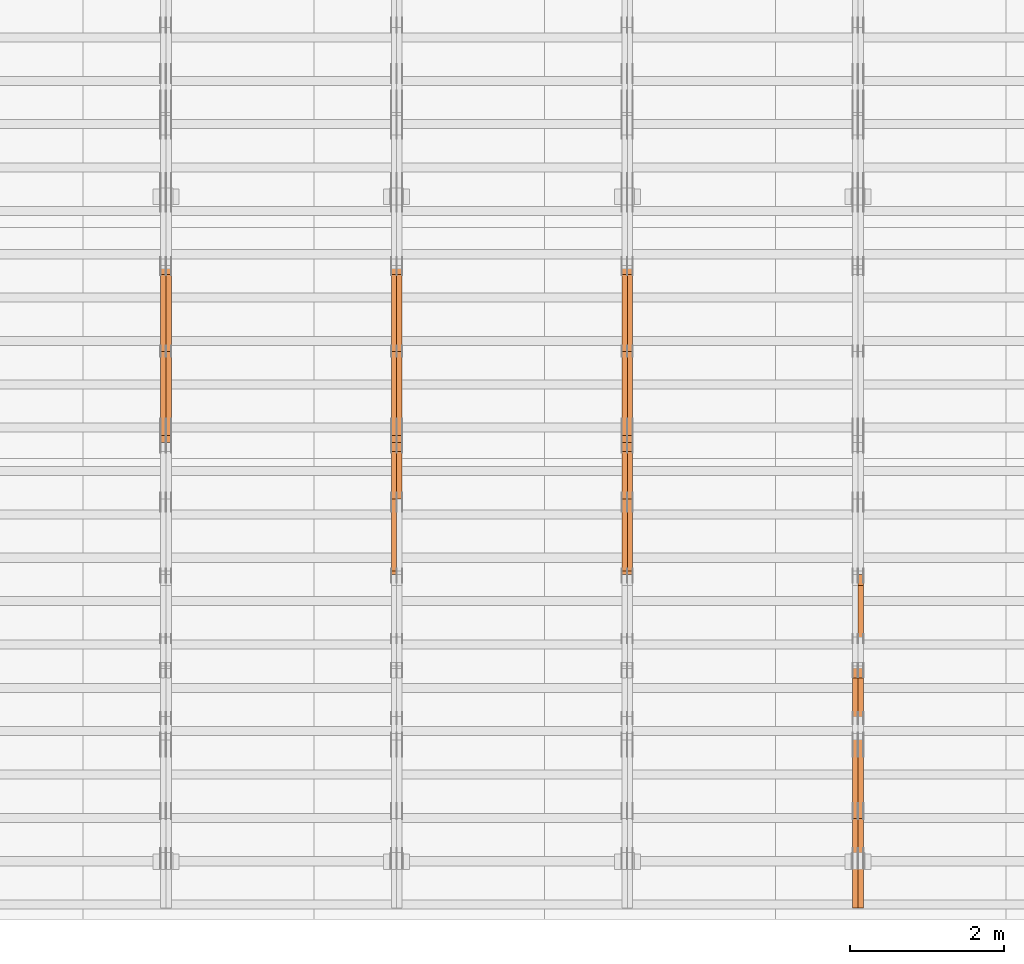
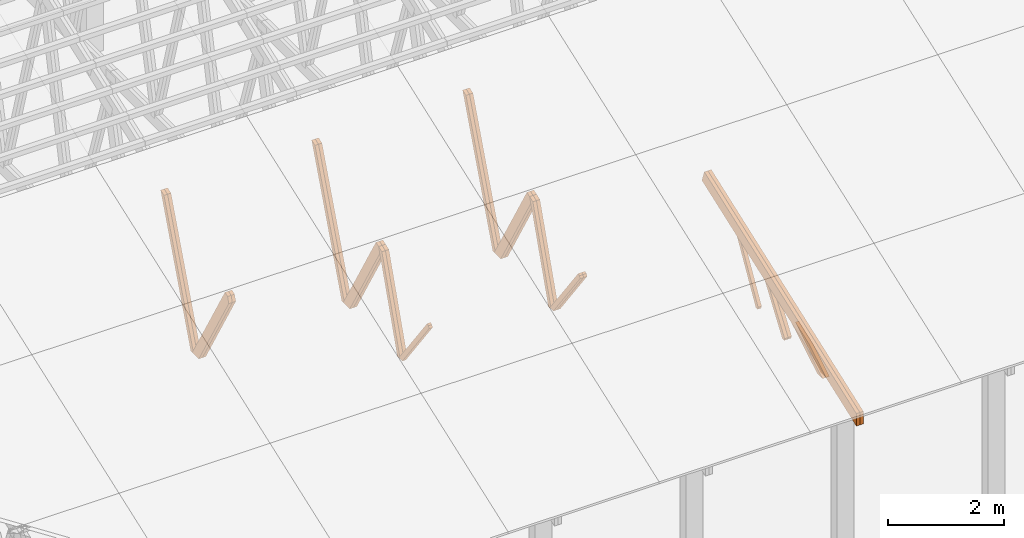
# One storey, part 22 of 189: 26 proxies.
"""IFC2X3 building model written with IfcOpenShell, lengths in millimetres."""

from ifc_helpers import new_model, entity, si_unit, converted_unit, derived_unit, direction, frame, origin, place, context, subcontext, project, spatial, polyline, outline, extrude, source, transform, mapped, material, type_object, type_shapes, element, save


model = new_model("IFC2X3")

# Units and contexts
model_context = context("Model", 3, precision=0.01, world=origin(), true_north=direction((6.12303176911189e-17, 1.0)))
body_context = subcontext(model_context, "Body", "Model", "MODEL_VIEW")
ifc_project = project(units=[si_unit("LENGTHUNIT", "METRE", prefix="MILLI"), si_unit("AREAUNIT", "SQUARE_METRE"), si_unit("VOLUMEUNIT", "CUBIC_METRE"), converted_unit("PLANEANGLEUNIT", "DEGREE", entity("IfcRatioMeasure", 0.0174532925199433), si_unit("PLANEANGLEUNIT", "RADIAN"), dimensions=[0, 0, 0, 0, 0, 0, 0]), si_unit("MASSUNIT", "GRAM", prefix="KILO"), derived_unit("MASSDENSITYUNIT", [(si_unit("MASSUNIT", "GRAM", prefix="KILO"), 1), (si_unit("LENGTHUNIT", "METRE"), -3)]), si_unit("TIMEUNIT", "SECOND"), si_unit("FREQUENCYUNIT", "HERTZ"), si_unit("THERMODYNAMICTEMPERATUREUNIT", "DEGREE_CELSIUS"), derived_unit("THERMALTRANSMITTANCEUNIT", [(si_unit("MASSUNIT", "GRAM", prefix="KILO"), 1), (si_unit("THERMODYNAMICTEMPERATUREUNIT", "KELVIN"), -1), (si_unit("TIMEUNIT", "SECOND"), -3)]), derived_unit("VOLUMETRICFLOWRATEUNIT", [(si_unit("LENGTHUNIT", "METRE"), 3), (si_unit("TIMEUNIT", "SECOND"), -1)]), si_unit("ELECTRICCURRENTUNIT", "AMPERE"), si_unit("ELECTRICVOLTAGEUNIT", "VOLT"), si_unit("POWERUNIT", "WATT"), si_unit("FORCEUNIT", "NEWTON"), si_unit("ILLUMINANCEUNIT", "LUX"), si_unit("LUMINOUSFLUXUNIT", "LUMEN"), si_unit("LUMINOUSINTENSITYUNIT", "CANDELA"), derived_unit("USERDEFINED", [(si_unit("MASSUNIT", "GRAM", prefix="KILO"), -1), (si_unit("LENGTHUNIT", "METRE"), -2), (si_unit("TIMEUNIT", "SECOND"), 3), (si_unit("LUMINOUSFLUXUNIT", "LUMEN"), 1)]), derived_unit("LINEARVELOCITYUNIT", [(si_unit("LENGTHUNIT", "METRE"), 1), (si_unit("TIMEUNIT", "SECOND"), -1)]), si_unit("PRESSUREUNIT", "PASCAL"), derived_unit("USERDEFINED", [(si_unit("LENGTHUNIT", "METRE"), -2), (si_unit("MASSUNIT", "GRAM", prefix="KILO"), 1), (si_unit("TIMEUNIT", "SECOND"), -2)])], contexts=[model_context])

# Site, building, storey
site_placement = place(None, origin())
site = spatial("IfcSite", under=ifc_project, at=site_placement, CompositionType="ELEMENT")
building_placement = place(site_placement, origin())
building = spatial("IfcBuilding", under=site, at=building_placement, CompositionType="ELEMENT")
storey_placement = place(building_placement, origin())
storey = spatial("IfcBuildingStorey", under=building, at=storey_placement, Name="Default", CompositionType="ELEMENT", Elevation=0.0)

# Proxies
ifc_material_1 = material(Name="IfcSurfaceStyle #129154")
building_element_proxy_type_1 = type_object("IfcBuildingElementProxyType", Name="T1-W11 129152", PredefinedType="NOTDEFINED", material=ifc_material_1)
shared_shape_1 = source(origin(), body_context, "Body", "SweptSolid", [
    extrude(outline(polyline([(593.358012843793, -552.565239103314), (742.388662259985, -552.565239103314), (-410.498749190676, 401.275038694583), (-462.246133468927, 382.44069706518), (-463.001792444175, 321.414742446865), (593.358012843793, -552.565239103314)])), frame((599.94412413079, 47.5003788877286, 0.0), z_axis=(0.0, 0.0, 1.0), x_axis=(0.770483455324544, 0.637459994879013, 0.0)), (0.0, 0.0, 1.0), 69.9999999999999),
])
type_shapes(building_element_proxy_type_1, [shared_shape_1])
proxy_1_placement = place(building_placement, frame((24300.0, 2983.26655629375, 269.034992751429), z_axis=(-1.0, 0.0, 0.0), x_axis=(0.0, 0.505995901100606, 0.862535882192379)))
element("IfcBuildingElementProxy", 1, at=proxy_1_placement, inside=storey, type_object=building_element_proxy_type_1, material=ifc_material_1, Name="T1-W11", context=body_context, shape_type="MappedRepresentation", body=[
    mapped(shared_shape_1, transform((0.0, 0.0, 0.0), scale=1.0)),
])
ifc_material_2 = material(Name="IfcSurfaceStyle #128626")
building_element_proxy_type_2 = type_object("IfcBuildingElementProxyType", Name="T1-W13 128624", PredefinedType="NOTDEFINED", material=ifc_material_2)
shared_shape_2 = source(origin(), body_context, "Body", "SweptSolid", [
    extrude(outline(polyline([(404.740440720218, -341.48092914206), (570.336320797765, -341.48092914206), (-287.911826743206, 259.650691447848), (-342.395697357435, 239.820346030744), (-344.769237417342, 183.490820805529), (404.740440720218, -341.48092914206)])), frame((418.029573061951, 47.5005675782689, 0.0), z_axis=(0.0, 0.0, 1.0), x_axis=(0.819070847746389, 0.573692379565924, 0.0)), (0.0, 0.0, 1.0), 69.9999999999999),
])
type_shapes(building_element_proxy_type_2, [shared_shape_2])
proxy_2_placement = place(building_placement, frame((24300.0, 1951.16403402681, 272.239720286334), z_axis=(-1.0, 0.0, 0.0), x_axis=(0.0, 0.573462629043499, 0.819231721242848)))
element("IfcBuildingElementProxy", 2, at=proxy_2_placement, inside=storey, type_object=building_element_proxy_type_2, material=ifc_material_2, Name="T1-W13", context=body_context, shape_type="MappedRepresentation", body=[
    mapped(shared_shape_2, transform((0.0, 0.0, 0.0), scale=1.0)),
])
ifc_material_3 = material(Name="IfcSurfaceStyle #128560")
building_element_proxy_type_3 = type_object("IfcBuildingElementProxyType", Name="T1-W13 128558", PredefinedType="NOTDEFINED", material=ifc_material_3)
shared_shape_3 = source(origin(), body_context, "Body", "SweptSolid", [
    extrude(outline(polyline([(404.740440720218, -341.48092914206), (570.336320797765, -341.48092914206), (-287.911826743206, 259.650691447848), (-342.395697357435, 239.820346030744), (-344.769237417342, 183.490820805529), (404.740440720218, -341.48092914206)])), frame((418.029573061951, 47.5005675782689, 0.0), z_axis=(0.0, 0.0, 1.0), x_axis=(0.819070847746389, 0.573692379565924, 0.0)), (0.0, 0.0, 1.0), 69.9999999999999),
])
type_shapes(building_element_proxy_type_3, [shared_shape_3])
proxy_3_placement = place(building_placement, frame((24230.0, 1951.16403402681, 272.239720286334), z_axis=(-1.0, 0.0, 0.0), x_axis=(0.0, 0.573462629043499, 0.819231721242848)))
element("IfcBuildingElementProxy", 3, at=proxy_3_placement, inside=storey, type_object=building_element_proxy_type_3, material=ifc_material_3, Name="T1-W13", context=body_context, shape_type="MappedRepresentation", body=[
    mapped(shared_shape_3, transform((0.0, 0.0, 0.0), scale=1.0)),
])
ifc_material_4 = material(Name="IfcSurfaceStyle #128098")
building_element_proxy_type_4 = type_object("IfcBuildingElementProxyType", Name="T1-W12 128096", PredefinedType="NOTDEFINED", material=ifc_material_4)
shared_shape_4 = source(origin(), body_context, "Body", "SweptSolid", [
    extrude(outline(polyline([(-671.888430889784, -47.499785620702), (344.892972119224, -47.499785620702), (503.856463083211, 47.4997856207019), (-176.861004312651, 47.499785620702), (-671.888430889784, -47.499785620702)])), frame((503.857114243549, 47.5002636410509, 0.0), z_axis=(0.0, 0.0, 1.0), x_axis=(-1.0, 0.0, 0.0)), (0.0, 0.0, 1.0), 69.9999999999999),
])
type_shapes(building_element_proxy_type_4, [shared_shape_4])
proxy_4_placement = place(building_placement, frame((24300.0, 665.58122707747, 245.000076287477), z_axis=(-1.0, 0.0, 0.0), x_axis=(0.0, 0.858392121304013, 0.51299411895576)))
element("IfcBuildingElementProxy", 4, at=proxy_4_placement, inside=storey, type_object=building_element_proxy_type_4, material=ifc_material_4, Name="T1-W12", context=body_context, shape_type="MappedRepresentation", body=[
    mapped(shared_shape_4, transform((0.0, 0.0, 0.0), scale=1.0)),
])
ifc_material_5 = material(Name="IfcSurfaceStyle #128041")
building_element_proxy_type_5 = type_object("IfcBuildingElementProxyType", Name="T1-W12 128039", PredefinedType="NOTDEFINED", material=ifc_material_5)
shared_shape_5 = source(origin(), body_context, "Body", "SweptSolid", [
    extrude(outline(polyline([(-671.888430889784, -47.499785620702), (344.892972119224, -47.499785620702), (503.856463083211, 47.4997856207019), (-176.861004312651, 47.499785620702), (-671.888430889784, -47.499785620702)])), frame((503.857114243549, 47.5002636410509, 0.0), z_axis=(0.0, 0.0, 1.0), x_axis=(-1.0, 0.0, 0.0)), (0.0, 0.0, 1.0), 69.9999999999999),
])
type_shapes(building_element_proxy_type_5, [shared_shape_5])
proxy_5_placement = place(building_placement, frame((24230.0, 665.58122707747, 245.000076287477), z_axis=(-1.0, 0.0, 0.0), x_axis=(0.0, 0.858392121304013, 0.51299411895576)))
element("IfcBuildingElementProxy", 5, at=proxy_5_placement, inside=storey, type_object=building_element_proxy_type_5, material=ifc_material_5, Name="T1-W12", context=body_context, shape_type="MappedRepresentation", body=[
    mapped(shared_shape_5, transform((0.0, 0.0, 0.0), scale=1.0)),
])
ifc_material_6 = material(Name="IfcSurfaceStyle #127150")
building_element_proxy_type_6 = type_object("IfcBuildingElementProxyType", Name="T1-T2 127148", PredefinedType="NOTDEFINED", material=ifc_material_6)
shared_shape_6 = source(origin(), body_context, "Body", "SweptSolid", [
    extrude(outline(polyline([(-2763.12044548193, -122.499971764318), (2807.70681121203, -122.499971764318), (2807.70678531127, 122.499971764318), (-2852.29315104137, 122.499971764318), (-2763.12044548193, -122.499971764318)])), frame((2807.70684902043, 122.500023191939, 0.0), z_axis=(0.0, 0.0, 1.0), x_axis=(-1.0, 0.0, 0.0)), (0.0, 0.0, 1.0), 69.9999999999997),
])
type_shapes(building_element_proxy_type_6, [shared_shape_6])
proxy_6_placement = place(building_placement, frame((24300.0, 4818.66023370631, 1893.1253396746), z_axis=(-1.0, 0.0, 0.0), x_axis=(0.0, -0.939692620785908, -0.342020143325669)))
element("IfcBuildingElementProxy", 6, at=proxy_6_placement, inside=storey, type_object=building_element_proxy_type_6, material=ifc_material_6, Name="T1-T2", context=body_context, shape_type="MappedRepresentation", body=[
    mapped(shared_shape_6, transform((0.0, 0.0, 0.0), scale=1.0)),
])
ifc_material_7 = material(Name="IfcSurfaceStyle #127093")
building_element_proxy_type_7 = type_object("IfcBuildingElementProxyType", Name="T1-T2 127091", PredefinedType="NOTDEFINED", material=ifc_material_7)
shared_shape_7 = source(origin(), body_context, "Body", "SweptSolid", [
    extrude(outline(polyline([(-2763.12044548193, -122.499971764318), (2807.70681121203, -122.499971764318), (2807.70678531127, 122.499971764318), (-2852.29315104137, 122.499971764318), (-2763.12044548193, -122.499971764318)])), frame((2807.70684902043, 122.500023191939, 0.0), z_axis=(0.0, 0.0, 1.0), x_axis=(-1.0, 0.0, 0.0)), (0.0, 0.0, 1.0), 69.9999999999997),
])
type_shapes(building_element_proxy_type_7, [shared_shape_7])
proxy_7_placement = place(building_placement, frame((24230.0, 4818.66023370631, 1893.1253396746), z_axis=(-1.0, 0.0, 0.0), x_axis=(0.0, -0.939692620785908, -0.342020143325669)))
element("IfcBuildingElementProxy", 7, at=proxy_7_placement, inside=storey, type_object=building_element_proxy_type_7, material=ifc_material_7, Name="T1-T2", context=body_context, shape_type="MappedRepresentation", body=[
    mapped(shared_shape_7, transform((0.0, 0.0, 0.0), scale=1.0)),
])
ifc_material_8 = material(Name="IfcSurfaceStyle #114420")
building_element_proxy_type_8 = type_object("IfcBuildingElementProxyType", Name="T1-W8 114418", PredefinedType="NOTDEFINED", material=ifc_material_8)
shared_shape_8 = source(origin(), body_context, "Body", "SweptSolid", [
    extrude(outline(polyline([(-1781.70529904483, -47.500320228718), (1161.65050357787, -47.5003202287179), (1179.56135870849, 0.000731866266039397), (1140.6022069428, 47.4998218997103), (-1700.10877018433, 47.5000866914596), (-1781.70529904483, -47.500320228718)])), frame((1179.56135870869, 47.5007236522113, 0.0), z_axis=(0.0, 0.0, 1.0), x_axis=(-1.0, 3.74658825645258e-07, 0.0)), (0.0, 0.0, 1.0), 69.9999999999998),
])
type_shapes(building_element_proxy_type_8, [shared_shape_8])
proxy_8_placement = place(building_placement, frame((21300.0, 6723.5697965901, 261.758864533503), z_axis=(-1.0, 0.0, 0.0), x_axis=(0.0, 0.352814979177603, 0.93569310698963)))
element("IfcBuildingElementProxy", 8, at=proxy_8_placement, inside=storey, type_object=building_element_proxy_type_8, material=ifc_material_8, Name="T1-W8", context=body_context, shape_type="MappedRepresentation", body=[
    mapped(shared_shape_8, transform((0.0, 0.0, 0.0), scale=1.0)),
])
ifc_material_9 = material(Name="IfcSurfaceStyle #114354")
building_element_proxy_type_9 = type_object("IfcBuildingElementProxyType", Name="T1-W8 114352", PredefinedType="NOTDEFINED", material=ifc_material_9)
shared_shape_9 = source(origin(), body_context, "Body", "SweptSolid", [
    extrude(outline(polyline([(-1781.70529904483, -47.500320228718), (1161.65050357787, -47.5003202287179), (1179.56135870849, 0.000731866266039397), (1140.6022069428, 47.4998218997103), (-1700.10877018433, 47.5000866914596), (-1781.70529904483, -47.500320228718)])), frame((1179.56135870869, 47.5007236522113, 0.0), z_axis=(0.0, 0.0, 1.0), x_axis=(-1.0, 3.74658825645258e-07, 0.0)), (0.0, 0.0, 1.0), 69.9999999999998),
])
type_shapes(building_element_proxy_type_9, [shared_shape_9])
proxy_9_placement = place(building_placement, frame((21230.0, 6723.5697965901, 261.758864533503), z_axis=(-1.0, 0.0, 0.0), x_axis=(0.0, 0.352814979177603, 0.93569310698963)))
element("IfcBuildingElementProxy", 9, at=proxy_9_placement, inside=storey, type_object=building_element_proxy_type_9, material=ifc_material_9, Name="T1-W8", context=body_context, shape_type="MappedRepresentation", body=[
    mapped(shared_shape_9, transform((0.0, 0.0, 0.0), scale=1.0)),
])
ifc_material_10 = material(Name="IfcSurfaceStyle #114156")
building_element_proxy_type_10 = type_object("IfcBuildingElementProxyType", Name="T1-W2 114154", PredefinedType="NOTDEFINED", material=ifc_material_10)
shared_shape_10 = source(origin(), body_context, "Body", "SweptSolid", [
    extrude(outline(polyline([(-765.033104991319, -1130.91940266317), (-539.905732758898, -1130.91940266317), (493.678280567457, 660.584515081422), (452.144945212405, 783.697385511457), (359.115611970356, 817.556904733455), (-765.033104991319, -1130.91940266317)])), frame((904.774360566371, 97.5002668805543, 0.0), z_axis=(0.0, 0.0, 1.0), x_axis=(-0.499731715721184, 0.866180242387438, 0.0)), (0.0, 0.0, 1.0), 69.9999999999998),
])
type_shapes(building_element_proxy_type_10, [shared_shape_10])
proxy_10_placement = place(building_placement, frame((21300.0, 5635.28919163287, 2208.3400784451), z_axis=(-1.0, 0.0, 0.0), x_axis=(0.0, 0.5, -0.866025403784439)))
element("IfcBuildingElementProxy", 10, at=proxy_10_placement, inside=storey, type_object=building_element_proxy_type_10, material=ifc_material_10, Name="T1-W2", context=body_context, shape_type="MappedRepresentation", body=[
    mapped(shared_shape_10, transform((0.0, 0.0, 0.0), scale=1.0)),
])
ifc_material_11 = material(Name="IfcSurfaceStyle #114090")
building_element_proxy_type_11 = type_object("IfcBuildingElementProxyType", Name="T1-W2 114088", PredefinedType="NOTDEFINED", material=ifc_material_11)
shared_shape_11 = source(origin(), body_context, "Body", "SweptSolid", [
    extrude(outline(polyline([(-765.033104991319, -1130.91940266317), (-539.905732758898, -1130.91940266317), (493.678280567457, 660.584515081422), (452.144945212405, 783.697385511457), (359.115611970356, 817.556904733455), (-765.033104991319, -1130.91940266317)])), frame((904.774360566371, 97.5002668805543, 0.0), z_axis=(0.0, 0.0, 1.0), x_axis=(-0.499731715721184, 0.866180242387438, 0.0)), (0.0, 0.0, 1.0), 69.9999999999998),
])
type_shapes(building_element_proxy_type_11, [shared_shape_11])
proxy_11_placement = place(building_placement, frame((21230.0, 5635.28919163287, 2208.3400784451), z_axis=(-1.0, 0.0, 0.0), x_axis=(0.0, 0.5, -0.866025403784439)))
element("IfcBuildingElementProxy", 11, at=proxy_11_placement, inside=storey, type_object=building_element_proxy_type_11, material=ifc_material_11, Name="T1-W2", context=body_context, shape_type="MappedRepresentation", body=[
    mapped(shared_shape_11, transform((0.0, 0.0, 0.0), scale=1.0)),
])
ifc_material_12 = material(Name="IfcSurfaceStyle #113892")
building_element_proxy_type_12 = type_object("IfcBuildingElementProxyType", Name="T1-W9 113890", PredefinedType="NOTDEFINED", material=ifc_material_12)
shared_shape_12 = source(origin(), body_context, "Body", "SweptSolid", [
    extrude(outline(polyline([(-1227.3969292634, -47.5000382896404), (793.242467803064, -47.5000382896404), (809.267705296822, 1.0956605530188e-05), (776.329919980315, 47.5000328113376), (-1151.4431638168, 47.5000328113376), (-1227.3969292634, -47.5000382896404)])), frame((809.267705296822, 47.5000328113376, 0.0), z_axis=(0.0, 0.0, 1.0), x_axis=(-1.0, 0.0, 0.0)), (0.0, 0.0, 1.0), 69.9999999999999),
])
type_shapes(building_element_proxy_type_12, [shared_shape_12])
proxy_12_placement = place(building_placement, frame((21300.0, 4809.76380889125, 260.184242613649), z_axis=(-1.0, 0.0, 0.0), x_axis=(0.0, 0.31966811847134, 0.947529574226047)))
element("IfcBuildingElementProxy", 12, at=proxy_12_placement, inside=storey, type_object=building_element_proxy_type_12, material=ifc_material_12, Name="T1-W9", context=body_context, shape_type="MappedRepresentation", body=[
    mapped(shared_shape_12, transform((0.0, 0.0, 0.0), scale=1.0)),
])
ifc_material_13 = material(Name="IfcSurfaceStyle #113826")
building_element_proxy_type_13 = type_object("IfcBuildingElementProxyType", Name="T1-W9 113824", PredefinedType="NOTDEFINED", material=ifc_material_13)
shared_shape_13 = source(origin(), body_context, "Body", "SweptSolid", [
    extrude(outline(polyline([(-1227.3969292634, -47.5000382896404), (793.242467803064, -47.5000382896404), (809.267705296822, 1.0956605530188e-05), (776.329919980315, 47.5000328113376), (-1151.4431638168, 47.5000328113376), (-1227.3969292634, -47.5000382896404)])), frame((809.267705296822, 47.5000328113376, 0.0), z_axis=(0.0, 0.0, 1.0), x_axis=(-1.0, 0.0, 0.0)), (0.0, 0.0, 1.0), 69.9999999999999),
])
type_shapes(building_element_proxy_type_13, [shared_shape_13])
proxy_13_placement = place(building_placement, frame((21230.0, 4809.76380889125, 260.184242613649), z_axis=(-1.0, 0.0, 0.0), x_axis=(0.0, 0.31966811847134, 0.947529574226047)))
element("IfcBuildingElementProxy", 13, at=proxy_13_placement, inside=storey, type_object=building_element_proxy_type_13, material=ifc_material_13, Name="T1-W9", context=body_context, shape_type="MappedRepresentation", body=[
    mapped(shared_shape_13, transform((0.0, 0.0, 0.0), scale=1.0)),
])
ifc_material_14 = material(Name="IfcSurfaceStyle #113628")
building_element_proxy_type_14 = type_object("IfcBuildingElementProxyType", Name="T1-W10 113626", PredefinedType="NOTDEFINED", material=ifc_material_14)
shared_shape_14 = source(origin(), body_context, "Body", "SweptSolid", [
    extrude(outline(polyline([(-922.639472665691, -47.5001890573134), (629.920966338637, -47.5001890573134), (650.067737483374, 0.000694680531158376), (635.89112756682, 47.4998417170478), (-993.240358723139, 47.4998417170478), (-922.639472665691, -47.5001890573134)])), frame((650.068202545693, 47.4999816623145, 0.0), z_axis=(0.0, 0.0, 1.0), x_axis=(-1.0, 0.0, 0.0)), (0.0, 0.0, 1.0), 69.9999999999999),
])
type_shapes(building_element_proxy_type_14, [shared_shape_14])
proxy_14_placement = place(building_placement, frame((21300.0, 3874.56126239818, 1563.95828147518), z_axis=(-1.0, 0.0, 0.0), x_axis=(0.0, 0.596486092002, -0.802623412347398)))
element("IfcBuildingElementProxy", 14, at=proxy_14_placement, inside=storey, type_object=building_element_proxy_type_14, material=ifc_material_14, Name="T1-W10", context=body_context, shape_type="MappedRepresentation", body=[
    mapped(shared_shape_14, transform((0.0, 0.0, 0.0), scale=1.0)),
])
ifc_material_15 = material(Name="IfcSurfaceStyle #113562")
building_element_proxy_type_15 = type_object("IfcBuildingElementProxyType", Name="T1-W10 113560", PredefinedType="NOTDEFINED", material=ifc_material_15)
shared_shape_15 = source(origin(), body_context, "Body", "SweptSolid", [
    extrude(outline(polyline([(-922.639472665691, -47.5001890573134), (629.920966338637, -47.5001890573134), (650.067737483374, 0.000694680531158376), (635.89112756682, 47.4998417170478), (-993.240358723139, 47.4998417170478), (-922.639472665691, -47.5001890573134)])), frame((650.068202545693, 47.4999816623145, 0.0), z_axis=(0.0, 0.0, 1.0), x_axis=(-1.0, 0.0, 0.0)), (0.0, 0.0, 1.0), 69.9999999999999),
])
type_shapes(building_element_proxy_type_15, [shared_shape_15])
proxy_15_placement = place(building_placement, frame((21230.0, 3874.56126239818, 1563.95828147518), z_axis=(-1.0, 0.0, 0.0), x_axis=(0.0, 0.596486092002, -0.802623412347398)))
element("IfcBuildingElementProxy", 15, at=proxy_15_placement, inside=storey, type_object=building_element_proxy_type_15, material=ifc_material_15, Name="T1-W10", context=body_context, shape_type="MappedRepresentation", body=[
    mapped(shared_shape_15, transform((0.0, 0.0, 0.0), scale=1.0)),
])
ifc_material_16 = material(Name="IfcSurfaceStyle #98630")
building_element_proxy_type_16 = type_object("IfcBuildingElementProxyType", Name="T1-W8 98628", PredefinedType="NOTDEFINED", material=ifc_material_16)
shared_shape_16 = source(origin(), body_context, "Body", "SweptSolid", [
    extrude(outline(polyline([(-1781.70529904483, -47.500320228718), (1161.65050357787, -47.5003202287179), (1179.56135870849, 0.000731866266039397), (1140.6022069428, 47.4998218997103), (-1700.10877018433, 47.5000866914596), (-1781.70529904483, -47.500320228718)])), frame((1179.56135870869, 47.5007236522113, 0.0), z_axis=(0.0, 0.0, 1.0), x_axis=(-1.0, 3.74658825645258e-07, 0.0)), (0.0, 0.0, 1.0), 69.9999999999998),
])
type_shapes(building_element_proxy_type_16, [shared_shape_16])
proxy_16_placement = place(building_placement, frame((18300.0, 6723.5697965901, 261.758864533503), z_axis=(-1.0, 0.0, 0.0), x_axis=(0.0, 0.352814979177603, 0.93569310698963)))
element("IfcBuildingElementProxy", 16, at=proxy_16_placement, inside=storey, type_object=building_element_proxy_type_16, material=ifc_material_16, Name="T1-W8", context=body_context, shape_type="MappedRepresentation", body=[
    mapped(shared_shape_16, transform((0.0, 0.0, 0.0), scale=1.0)),
])
ifc_material_17 = material(Name="IfcSurfaceStyle #98564")
building_element_proxy_type_17 = type_object("IfcBuildingElementProxyType", Name="T1-W8 98562", PredefinedType="NOTDEFINED", material=ifc_material_17)
shared_shape_17 = source(origin(), body_context, "Body", "SweptSolid", [
    extrude(outline(polyline([(-1781.70529904483, -47.500320228718), (1161.65050357787, -47.5003202287179), (1179.56135870849, 0.000731866266039397), (1140.6022069428, 47.4998218997103), (-1700.10877018433, 47.5000866914596), (-1781.70529904483, -47.500320228718)])), frame((1179.56135870869, 47.5007236522113, 0.0), z_axis=(0.0, 0.0, 1.0), x_axis=(-1.0, 3.74658825645258e-07, 0.0)), (0.0, 0.0, 1.0), 69.9999999999998),
])
type_shapes(building_element_proxy_type_17, [shared_shape_17])
proxy_17_placement = place(building_placement, frame((18230.0, 6723.5697965901, 261.758864533503), z_axis=(-1.0, 0.0, 0.0), x_axis=(0.0, 0.352814979177603, 0.93569310698963)))
element("IfcBuildingElementProxy", 17, at=proxy_17_placement, inside=storey, type_object=building_element_proxy_type_17, material=ifc_material_17, Name="T1-W8", context=body_context, shape_type="MappedRepresentation", body=[
    mapped(shared_shape_17, transform((0.0, 0.0, 0.0), scale=1.0)),
])
ifc_material_18 = material(Name="IfcSurfaceStyle #98366")
building_element_proxy_type_18 = type_object("IfcBuildingElementProxyType", Name="T1-W2 98364", PredefinedType="NOTDEFINED", material=ifc_material_18)
shared_shape_18 = source(origin(), body_context, "Body", "SweptSolid", [
    extrude(outline(polyline([(-765.033104991319, -1130.91940266317), (-539.905732758898, -1130.91940266317), (493.678280567457, 660.584515081422), (452.144945212405, 783.697385511457), (359.115611970356, 817.556904733455), (-765.033104991319, -1130.91940266317)])), frame((904.774360566371, 97.5002668805543, 0.0), z_axis=(0.0, 0.0, 1.0), x_axis=(-0.499731715721184, 0.866180242387438, 0.0)), (0.0, 0.0, 1.0), 69.9999999999998),
])
type_shapes(building_element_proxy_type_18, [shared_shape_18])
proxy_18_placement = place(building_placement, frame((18300.0, 5635.28919163287, 2208.3400784451), z_axis=(-1.0, 0.0, 0.0), x_axis=(0.0, 0.5, -0.866025403784439)))
element("IfcBuildingElementProxy", 18, at=proxy_18_placement, inside=storey, type_object=building_element_proxy_type_18, material=ifc_material_18, Name="T1-W2", context=body_context, shape_type="MappedRepresentation", body=[
    mapped(shared_shape_18, transform((0.0, 0.0, 0.0), scale=1.0)),
])
ifc_material_19 = material(Name="IfcSurfaceStyle #98300")
building_element_proxy_type_19 = type_object("IfcBuildingElementProxyType", Name="T1-W2 98298", PredefinedType="NOTDEFINED", material=ifc_material_19)
shared_shape_19 = source(origin(), body_context, "Body", "SweptSolid", [
    extrude(outline(polyline([(-765.033104991319, -1130.91940266317), (-539.905732758898, -1130.91940266317), (493.678280567457, 660.584515081422), (452.144945212405, 783.697385511457), (359.115611970356, 817.556904733455), (-765.033104991319, -1130.91940266317)])), frame((904.774360566371, 97.5002668805543, 0.0), z_axis=(0.0, 0.0, 1.0), x_axis=(-0.499731715721184, 0.866180242387438, 0.0)), (0.0, 0.0, 1.0), 69.9999999999998),
])
type_shapes(building_element_proxy_type_19, [shared_shape_19])
proxy_19_placement = place(building_placement, frame((18230.0, 5635.28919163287, 2208.3400784451), z_axis=(-1.0, 0.0, 0.0), x_axis=(0.0, 0.5, -0.866025403784439)))
element("IfcBuildingElementProxy", 19, at=proxy_19_placement, inside=storey, type_object=building_element_proxy_type_19, material=ifc_material_19, Name="T1-W2", context=body_context, shape_type="MappedRepresentation", body=[
    mapped(shared_shape_19, transform((0.0, 0.0, 0.0), scale=1.0)),
])
ifc_material_20 = material(Name="IfcSurfaceStyle #98102")
building_element_proxy_type_20 = type_object("IfcBuildingElementProxyType", Name="T1-W9 98100", PredefinedType="NOTDEFINED", material=ifc_material_20)
shared_shape_20 = source(origin(), body_context, "Body", "SweptSolid", [
    extrude(outline(polyline([(-1227.3969292634, -47.5000382896404), (793.242467803064, -47.5000382896404), (809.267705296822, 1.0956605530188e-05), (776.329919980315, 47.5000328113376), (-1151.4431638168, 47.5000328113376), (-1227.3969292634, -47.5000382896404)])), frame((809.267705296822, 47.5000328113376, 0.0), z_axis=(0.0, 0.0, 1.0), x_axis=(-1.0, 0.0, 0.0)), (0.0, 0.0, 1.0), 69.9999999999999),
])
type_shapes(building_element_proxy_type_20, [shared_shape_20])
proxy_20_placement = place(building_placement, frame((18300.0, 4809.76380889125, 260.184242613649), z_axis=(-1.0, 0.0, 0.0), x_axis=(0.0, 0.31966811847134, 0.947529574226047)))
element("IfcBuildingElementProxy", 20, at=proxy_20_placement, inside=storey, type_object=building_element_proxy_type_20, material=ifc_material_20, Name="T1-W9", context=body_context, shape_type="MappedRepresentation", body=[
    mapped(shared_shape_20, transform((0.0, 0.0, 0.0), scale=1.0)),
])
ifc_material_21 = material(Name="IfcSurfaceStyle #98036")
building_element_proxy_type_21 = type_object("IfcBuildingElementProxyType", Name="T1-W9 98034", PredefinedType="NOTDEFINED", material=ifc_material_21)
shared_shape_21 = source(origin(), body_context, "Body", "SweptSolid", [
    extrude(outline(polyline([(-1227.3969292634, -47.5000382896404), (793.242467803064, -47.5000382896404), (809.267705296822, 1.0956605530188e-05), (776.329919980315, 47.5000328113376), (-1151.4431638168, 47.5000328113376), (-1227.3969292634, -47.5000382896404)])), frame((809.267705296822, 47.5000328113376, 0.0), z_axis=(0.0, 0.0, 1.0), x_axis=(-1.0, 0.0, 0.0)), (0.0, 0.0, 1.0), 69.9999999999999),
])
type_shapes(building_element_proxy_type_21, [shared_shape_21])
proxy_21_placement = place(building_placement, frame((18230.0, 4809.76380889125, 260.184242613649), z_axis=(-1.0, 0.0, 0.0), x_axis=(0.0, 0.31966811847134, 0.947529574226047)))
element("IfcBuildingElementProxy", 21, at=proxy_21_placement, inside=storey, type_object=building_element_proxy_type_21, material=ifc_material_21, Name="T1-W9", context=body_context, shape_type="MappedRepresentation", body=[
    mapped(shared_shape_21, transform((0.0, 0.0, 0.0), scale=1.0)),
])
ifc_material_22 = material(Name="IfcSurfaceStyle #97772")
building_element_proxy_type_22 = type_object("IfcBuildingElementProxyType", Name="T1-W10 97770", PredefinedType="NOTDEFINED", material=ifc_material_22)
shared_shape_22 = source(origin(), body_context, "Body", "SweptSolid", [
    extrude(outline(polyline([(-922.639472665691, -47.5001890573134), (629.920966338637, -47.5001890573134), (650.067737483374, 0.000694680531158376), (635.89112756682, 47.4998417170478), (-993.240358723139, 47.4998417170478), (-922.639472665691, -47.5001890573134)])), frame((650.068202545693, 47.4999816623145, 0.0), z_axis=(0.0, 0.0, 1.0), x_axis=(-1.0, 0.0, 0.0)), (0.0, 0.0, 1.0), 69.9999999999999),
])
type_shapes(building_element_proxy_type_22, [shared_shape_22])
proxy_22_placement = place(building_placement, frame((18230.0, 3874.56126239818, 1563.95828147518), z_axis=(-1.0, 0.0, 0.0), x_axis=(0.0, 0.596486092002, -0.802623412347398)))
element("IfcBuildingElementProxy", 22, at=proxy_22_placement, inside=storey, type_object=building_element_proxy_type_22, material=ifc_material_22, Name="T1-W10", context=body_context, shape_type="MappedRepresentation", body=[
    mapped(shared_shape_22, transform((0.0, 0.0, 0.0), scale=1.0)),
])
ifc_material_23 = material(Name="IfcSurfaceStyle #82840")
building_element_proxy_type_23 = type_object("IfcBuildingElementProxyType", Name="T1-W8 82838", PredefinedType="NOTDEFINED", material=ifc_material_23)
shared_shape_23 = source(origin(), body_context, "Body", "SweptSolid", [
    extrude(outline(polyline([(-1781.70529904483, -47.500320228718), (1161.65050357787, -47.5003202287179), (1179.56135870849, 0.000731866266039397), (1140.6022069428, 47.4998218997103), (-1700.10877018433, 47.5000866914596), (-1781.70529904483, -47.500320228718)])), frame((1179.56135870869, 47.5007236522113, 0.0), z_axis=(0.0, 0.0, 1.0), x_axis=(-1.0, 3.74658825645258e-07, 0.0)), (0.0, 0.0, 1.0), 69.9999999999998),
])
type_shapes(building_element_proxy_type_23, [shared_shape_23])
proxy_23_placement = place(building_placement, frame((15300.0, 6723.5697965901, 261.758864533503), z_axis=(-1.0, 0.0, 0.0), x_axis=(0.0, 0.352814979177603, 0.93569310698963)))
element("IfcBuildingElementProxy", 23, at=proxy_23_placement, inside=storey, type_object=building_element_proxy_type_23, material=ifc_material_23, Name="T1-W8", context=body_context, shape_type="MappedRepresentation", body=[
    mapped(shared_shape_23, transform((0.0, 0.0, 0.0), scale=1.0)),
])
ifc_material_24 = material(Name="IfcSurfaceStyle #82774")
building_element_proxy_type_24 = type_object("IfcBuildingElementProxyType", Name="T1-W8 82772", PredefinedType="NOTDEFINED", material=ifc_material_24)
shared_shape_24 = source(origin(), body_context, "Body", "SweptSolid", [
    extrude(outline(polyline([(-1781.70529904483, -47.500320228718), (1161.65050357787, -47.5003202287179), (1179.56135870849, 0.000731866266039397), (1140.6022069428, 47.4998218997103), (-1700.10877018433, 47.5000866914596), (-1781.70529904483, -47.500320228718)])), frame((1179.56135870869, 47.5007236522113, 0.0), z_axis=(0.0, 0.0, 1.0), x_axis=(-1.0, 3.74658825645258e-07, 0.0)), (0.0, 0.0, 1.0), 69.9999999999998),
])
type_shapes(building_element_proxy_type_24, [shared_shape_24])
proxy_24_placement = place(building_placement, frame((15230.0, 6723.5697965901, 261.758864533503), z_axis=(-1.0, 0.0, 0.0), x_axis=(0.0, 0.352814979177603, 0.93569310698963)))
element("IfcBuildingElementProxy", 24, at=proxy_24_placement, inside=storey, type_object=building_element_proxy_type_24, material=ifc_material_24, Name="T1-W8", context=body_context, shape_type="MappedRepresentation", body=[
    mapped(shared_shape_24, transform((0.0, 0.0, 0.0), scale=1.0)),
])
ifc_material_25 = material(Name="IfcSurfaceStyle #82576")
building_element_proxy_type_25 = type_object("IfcBuildingElementProxyType", Name="T1-W2 82574", PredefinedType="NOTDEFINED", material=ifc_material_25)
shared_shape_25 = source(origin(), body_context, "Body", "SweptSolid", [
    extrude(outline(polyline([(-765.033104991319, -1130.91940266317), (-539.905732758898, -1130.91940266317), (493.678280567457, 660.584515081422), (452.144945212405, 783.697385511457), (359.115611970356, 817.556904733455), (-765.033104991319, -1130.91940266317)])), frame((904.774360566371, 97.5002668805543, 0.0), z_axis=(0.0, 0.0, 1.0), x_axis=(-0.499731715721184, 0.866180242387438, 0.0)), (0.0, 0.0, 1.0), 69.9999999999998),
])
type_shapes(building_element_proxy_type_25, [shared_shape_25])
proxy_25_placement = place(building_placement, frame((15300.0, 5635.28919163287, 2208.3400784451), z_axis=(-1.0, 0.0, 0.0), x_axis=(0.0, 0.5, -0.866025403784439)))
element("IfcBuildingElementProxy", 25, at=proxy_25_placement, inside=storey, type_object=building_element_proxy_type_25, material=ifc_material_25, Name="T1-W2", context=body_context, shape_type="MappedRepresentation", body=[
    mapped(shared_shape_25, transform((0.0, 0.0, 0.0), scale=1.0)),
])
ifc_material_26 = material(Name="IfcSurfaceStyle #82510")
building_element_proxy_type_26 = type_object("IfcBuildingElementProxyType", Name="T1-W2 82508", PredefinedType="NOTDEFINED", material=ifc_material_26)
shared_shape_26 = source(origin(), body_context, "Body", "SweptSolid", [
    extrude(outline(polyline([(-765.033104991319, -1130.91940266317), (-539.905732758898, -1130.91940266317), (493.678280567457, 660.584515081422), (452.144945212405, 783.697385511457), (359.115611970356, 817.556904733455), (-765.033104991319, -1130.91940266317)])), frame((904.774360566371, 97.5002668805543, 0.0), z_axis=(0.0, 0.0, 1.0), x_axis=(-0.499731715721184, 0.866180242387438, 0.0)), (0.0, 0.0, 1.0), 69.9999999999998),
])
type_shapes(building_element_proxy_type_26, [shared_shape_26])
proxy_26_placement = place(building_placement, frame((15230.0, 5635.28919163287, 2208.3400784451), z_axis=(-1.0, 0.0, 0.0), x_axis=(0.0, 0.5, -0.866025403784439)))
element("IfcBuildingElementProxy", 26, at=proxy_26_placement, inside=storey, type_object=building_element_proxy_type_26, material=ifc_material_26, Name="T1-W2", context=body_context, shape_type="MappedRepresentation", body=[
    mapped(shared_shape_26, transform((0.0, 0.0, 0.0), scale=1.0)),
])

save(model, "model.ifc")
